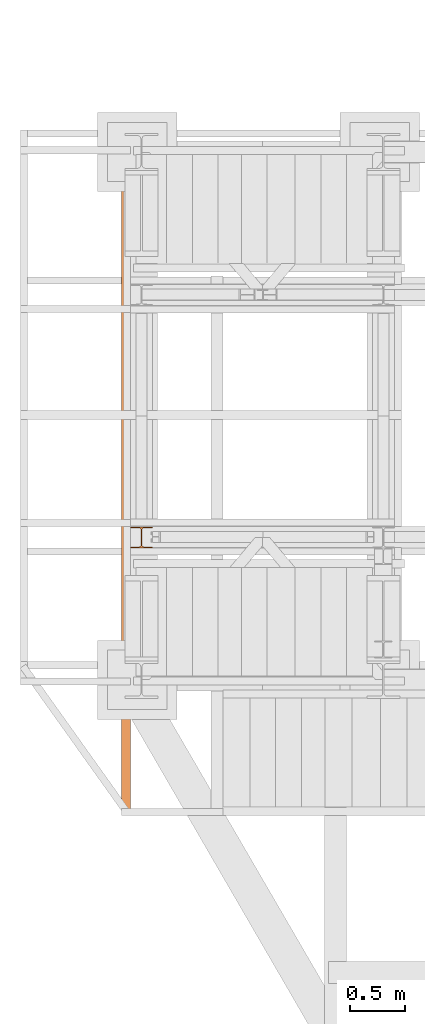
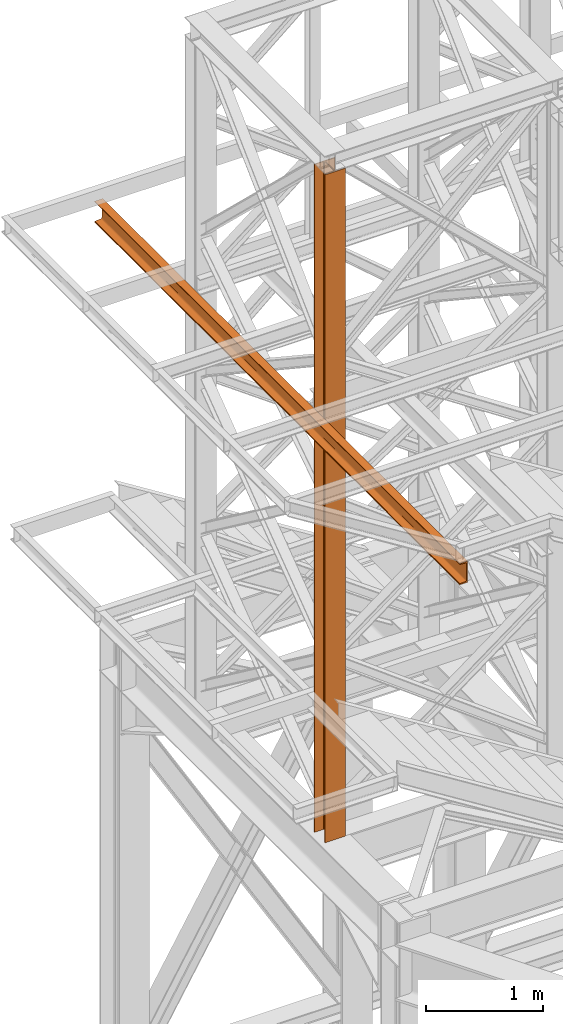
# One storey, part 83 of 208: 2 proxies.
"""IFC2X3 building model written with IfcOpenShell, lengths in millimetres."""

from ifc_helpers import new_model, entity, si_unit, converted_unit, frame, origin, origin_with_axes, place, context, subcontext, project, spatial, faceted_brep, element, save


model = new_model("IFC2X3")

# Units and contexts
model_context = context("Model", 3, precision=1e-05, world=origin())
plan_context = context("Plan", 3, precision=1e-05, world=origin())
body_context = subcontext(model_context, "Body", "Model", "MODEL_VIEW")
ifc_project = project(units=[si_unit("LENGTHUNIT", "METRE", prefix="MILLI"), converted_unit("PLANEANGLEUNIT", "DEGREE", entity("IfcPlaneAngleMeasure", 0.0174532925199433), si_unit("PLANEANGLEUNIT", "RADIAN"), dimensions=[0, 0, 0, 0, 0, 0, 0]), si_unit("AREAUNIT", "SQUARE_METRE"), si_unit("VOLUMEUNIT", "CUBIC_METRE")], contexts=[model_context, plan_context])

# Building, storey
building_placement = place(None, origin())
building = spatial("IfcBuilding", under=ifc_project, at=building_placement, CompositionType="COMPLEX")
storey_placement = place(building_placement, origin_with_axes())
storey = spatial("IfcBuildingStorey", under=building, at=storey_placement, Name="Geschoss", CompositionType="ELEMENT")

# Proxies
proxy_1_placement = place(storey_placement, frame((-3406.582754329113, -16062.574391808, 5284.990005364419), z_axis=(0.0, 0.0, 1.0), x_axis=(1.0, 0.0, 0.0)))
element("IfcBuildingElementProxy", 1, at=proxy_1_placement, inside=storey, context=body_context, shape_type="Brep", body=[
    faceted_brep([(0.01000000000021828, 190.0100125169756, 6965.010053329391), (200.0100029802325, 190.0100125169756, 6965.010053329391), (200.0100029802325, 180.0100146031382, 6965.010053329391), (121.2600035762789, 180.0100071525576, 6965.010053329391), (111.9441915473344, 178.1454621052744, 6965.010053329391), (105.1245498640838, 171.3258190250399, 6965.010053329391), (103.2600015571716, 162.010007927418, 6965.010053329391), (103.2600015571716, 28.00999713897727, 6965.010053329391), (105.1245498640838, 18.69418604135535, 6965.010053329391), (111.9441915473344, 11.87454296112082, 6965.010053329391), (121.2600035762789, 10.00999791383765, 6965.010053329391), (200.0100029802325, 10.00999791383765, 6965.010053329391), (200.0100029802325, 0.01000000000021828, 6965.010053329391), (0.01000000000021828, 0.01000000000021828, 6965.010053329391), (0.01000000000021828, 10.00999791383765, 6965.010053329391), (78.75999940395377, 10.00999791383765, 6965.010053329391), (88.07581143289826, 11.87454296112082, 6965.010053329391), (94.89545311614893, 18.69418604135535, 6965.010053329391), (96.76000142306111, 28.00999713897727, 6965.010053329391), (96.76000142306111, 162.010007927418, 6965.010053329391), (94.89545311614893, 171.3258190250399, 6965.010053329391), (88.07581143289826, 178.1454621052744, 6965.010053329391), (78.75999940395377, 180.0100071525576, 6965.010053329391), (0.01000000000021828, 180.0100146031382, 6965.010053329391), (200.0100029802325, 190.0100125169756, 6965.010053329391), (0.01000000000021828, 190.0100125169756, 6965.010053329391), (0.01000000000203727, 190.0100125169756, 0.009999999999308784), (200.0100029802343, 190.0100125169756, 0.009999999999308784), (200.0100029802325, 180.0100146031382, 6965.010053329391), (200.0100029802325, 190.0100125169756, 6965.010053329391), (200.0100029802343, 190.0100125169756, 0.009999999999308784), (200.0100029802343, 180.0100146031382, 0.009999999999308784), (121.2600035762789, 180.0100071525576, 6965.010053329391), (200.0100029802325, 180.0100146031382, 6965.010053329391), (200.0100029802343, 180.0100146031382, 0.009999999999308784), (121.2600035762807, 180.0100071525576, 0.009999999999308784), (111.9441915473344, 178.1454621052744, 6965.010053329391), (121.2600035762789, 180.0100071525576, 6965.010053329391), (121.2600035762807, 180.0100071525576, 0.009999999999308784), (111.9441915473362, 178.1454621052744, 0.009999999999308784), (105.1245498640838, 171.3258190250399, 6965.010053329391), (111.9441915473344, 178.1454621052744, 6965.010053329391), (111.9441915473362, 178.1454621052744, 0.009999999999308784), (105.1245498640856, 171.3258190250399, 0.009999999999308784), (103.2600015571716, 162.010007927418, 6965.010053329391), (105.1245498640838, 171.3258190250399, 6965.010053329391), (105.1245498640856, 171.3258190250399, 0.009999999999308784), (103.2600015571734, 162.010007927418, 0.009999999999308784), (103.2600015571716, 28.00999713897727, 6965.010053329391), (103.2600015571716, 162.010007927418, 6965.010053329391), (103.2600015571734, 162.010007927418, 0.009999999999308784), (103.2600015571734, 28.00999713897727, 0.009999999999308784), (105.1245498640838, 18.69418604135535, 6965.010053329391), (103.2600015571716, 28.00999713897727, 6965.010053329391), (103.2600015571734, 28.00999713897727, 0.009999999999308784), (105.1245498640856, 18.69418604135535, 0.009999999999308784), (111.9441915473344, 11.87454296112082, 6965.010053329391), (105.1245498640838, 18.69418604135535, 6965.010053329391), (105.1245498640856, 18.69418604135535, 0.009999999999308784), (111.9441915473362, 11.87454296112082, 0.009999999999308784), (121.2600035762789, 10.00999791383765, 6965.010053329391), (111.9441915473344, 11.87454296112082, 6965.010053329391), (111.9441915473362, 11.87454296112082, 0.009999999999308784), (121.2600035762807, 10.00999791383765, 0.009999999999308784), (200.0100029802325, 10.00999791383765, 6965.010053329391), (121.2600035762789, 10.00999791383765, 6965.010053329391), (121.2600035762807, 10.00999791383765, 0.009999999999308784), (200.0100029802343, 10.00999791383765, 0.009999999999308784), (200.0100029802325, 0.01000000000021828, 6965.010053329391), (200.0100029802325, 10.00999791383765, 6965.010053329391), (200.0100029802343, 10.00999791383765, 0.009999999999308784), (200.0100029802343, 0.01000000000021828, 0.009999999999308784), (0.01000000000021828, 0.01000000000021828, 6965.010053329391), (200.0100029802325, 0.01000000000021828, 6965.010053329391), (200.0100029802343, 0.01000000000021828, 0.009999999999308784), (0.01000000000203727, 0.01000000000021828, 0.009999999999308784), (0.01000000000021828, 10.00999791383765, 6965.010053329391), (0.01000000000021828, 0.01000000000021828, 6965.010053329391), (0.01000000000203727, 0.01000000000021828, 0.009999999999308784), (0.01000000000203727, 10.00999791383765, 0.009999999999308784), (78.75999940395377, 10.00999791383765, 6965.010053329391), (0.01000000000021828, 10.00999791383765, 6965.010053329391), (0.01000000000203727, 10.00999791383765, 0.009999999999308784), (78.75999940395559, 10.00999791383765, 0.009999999999308784), (88.07581143289826, 11.87454296112082, 6965.010053329391), (78.75999940395377, 10.00999791383765, 6965.010053329391), (78.75999940395559, 10.00999791383765, 0.009999999999308784), (88.07581143290008, 11.87454296112082, 0.009999999999308784), (94.89545311614893, 18.69418604135535, 6965.010053329391), (88.07581143289826, 11.87454296112082, 6965.010053329391), (88.07581143290008, 11.87454296112082, 0.009999999999308784), (94.89545311615075, 18.69418604135535, 0.009999999999308784), (96.76000142306111, 28.00999713897727, 6965.010053329391), (94.89545311614893, 18.69418604135535, 6965.010053329391), (94.89545311615075, 18.69418604135535, 0.009999999999308784), (96.76000142306293, 28.00999713897727, 0.009999999999308784), (96.76000142306111, 162.010007927418, 6965.010053329391), (96.76000142306111, 28.00999713897727, 6965.010053329391), (96.76000142306293, 28.00999713897727, 0.009999999999308784), (96.76000142306293, 162.010007927418, 0.009999999999308784), (94.89545311614893, 171.3258190250399, 6965.010053329391), (96.76000142306111, 162.010007927418, 6965.010053329391), (96.76000142306293, 162.010007927418, 0.009999999999308784), (94.89545311615075, 171.3258190250399, 0.009999999999308784), (88.07581143289826, 178.1454621052744, 6965.010053329391), (94.89545311614893, 171.3258190250399, 6965.010053329391), (94.89545311615075, 171.3258190250399, 0.009999999999308784), (88.07581143290008, 178.1454621052744, 0.009999999999308784), (78.75999940395377, 180.0100071525576, 6965.010053329391), (88.07581143289826, 178.1454621052744, 6965.010053329391), (88.07581143290008, 178.1454621052744, 0.009999999999308784), (78.75999940395559, 180.0100071525576, 0.009999999999308784), (0.01000000000021828, 180.0100146031382, 6965.010053329391), (78.75999940395377, 180.0100071525576, 6965.010053329391), (78.75999940395559, 180.0100071525576, 0.009999999999308784), (0.01000000000203727, 180.0100146031382, 0.009999999999308784), (0.01000000000021828, 190.0100125169756, 6965.010053329391), (0.01000000000021828, 180.0100146031382, 6965.010053329391), (0.01000000000203727, 180.0100146031382, 0.009999999999308784), (0.01000000000203727, 190.0100125169756, 0.009999999999308784), (0.01000000000203727, 190.0100125169756, 0.009999999999308784), (0.01000000000203727, 180.0100146031382, 0.009999999999308784), (78.75999940395559, 180.0100071525576, 0.009999999999308784), (88.07581143290008, 178.1454621052744, 0.009999999999308784), (94.89545311615075, 171.3258190250399, 0.009999999999308784), (96.76000142306293, 162.010007927418, 0.009999999999308784), (96.76000142306293, 28.00999713897727, 0.009999999999308784), (94.89545311615075, 18.69418604135535, 0.009999999999308784), (88.07581143290008, 11.87454296112082, 0.009999999999308784), (78.75999940395559, 10.00999791383765, 0.009999999999308784), (0.01000000000203727, 10.00999791383765, 0.009999999999308784), (0.01000000000203727, 0.01000000000021828, 0.009999999999308784), (200.0100029802343, 0.01000000000021828, 0.009999999999308784), (200.0100029802343, 10.00999791383765, 0.009999999999308784), (121.2600035762807, 10.00999791383765, 0.009999999999308784), (111.9441915473362, 11.87454296112082, 0.009999999999308784), (105.1245498640856, 18.69418604135535, 0.009999999999308784), (103.2600015571734, 28.00999713897727, 0.009999999999308784), (103.2600015571734, 162.010007927418, 0.009999999999308784), (105.1245498640856, 171.3258190250399, 0.009999999999308784), (111.9441915473362, 178.1454621052744, 0.009999999999308784), (121.2600035762807, 180.0100071525576, 0.009999999999308784), (200.0100029802343, 180.0100146031382, 0.009999999999308784), (200.0100029802343, 190.0100125169756, 0.009999999999308784)], [[[0, 1, 2, 3, 4, 5, 6, 7, 8, 9, 10, 11, 12, 13, 14, 15, 16, 17, 18, 19, 20, 21, 22, 23]], [[24, 25, 26, 27]], [[28, 29, 30, 31]], [[32, 33, 34, 35]], [[36, 37, 38, 39]], [[40, 41, 42, 43]], [[44, 45, 46, 47]], [[48, 49, 50, 51]], [[52, 53, 54, 55]], [[56, 57, 58, 59]], [[60, 61, 62, 63]], [[64, 65, 66, 67]], [[68, 69, 70, 71]], [[72, 73, 74, 75]], [[76, 77, 78, 79]], [[80, 81, 82, 83]], [[84, 85, 86, 87]], [[88, 89, 90, 91]], [[92, 93, 94, 95]], [[96, 97, 98, 99]], [[100, 101, 102, 103]], [[104, 105, 106, 107]], [[108, 109, 110, 111]], [[112, 113, 114, 115]], [[116, 117, 118, 119]], [[120, 121, 122, 123, 124, 125, 126, 127, 128, 129, 130, 131, 132, 133, 134, 135, 136, 137, 138, 139, 140, 141, 142, 143]]], orient=[[False], [False], [False], [False], [False], [False], [False], [False], [False], [False], [False], [False], [False], [False], [False], [False], [False], [False], [False], [False], [False], [False], [False], [False], [False], [False]]),
])
proxy_2_placement = place(storey_placement, frame((-3486.745032961433, -18497.5746220012, 9479.99), z_axis=(0.0, 0.0, 1.0), x_axis=(1.0, 0.0, 0.0)))
element("IfcBuildingElementProxy", 2, at=proxy_2_placement, inside=storey, context=body_context, shape_type="Brep", body=[
    faceted_brep([(0.4659155496847234, 6234.879120193393, 220.0100000000002), (0.01000000000021828, 0.00999999999839929, 220.0100000000002), (0.01000000000021828, 0.00999999999839929, 216.3507668260718), (0.4659155496847234, 6234.879120193393, 216.3507668260718), (0.4659155496847234, 6234.879120193393, 216.3507668260718), (0.01000000000021828, 0.00999999999839929, 216.3507668260718), (0.2968705002967909, 0.00999999999839929, 214.4411131085253), (0.752786049981296, 6234.879120193393, 214.4411131085253), (0.752786049981296, 6234.879120193393, 214.4411131085253), (0.2968705002967909, 0.00999999999839929, 214.4411131085253), (1.132098207624949, 0.00999999999839929, 212.7000047486563), (1.588013757309454, 6234.879120193393, 212.7000047486563), (1.588013757309454, 6234.879120193393, 212.7000047486563), (1.132098207624949, 0.00999999999839929, 212.7000047486563), (2.44200260908292, 0.00999999999839929, 211.281122986331), (2.897918158767425, 6234.879120193393, 211.281122986331), (2.897918158767425, 6234.879120193393, 211.281122986331), (2.44200260908292, 0.00999999999839929, 211.281122986331), (4.110960604608408, 0.00999999999839929, 210.3097101734329), (4.566876154294732, 6234.879120193393, 210.3097101734329), (4.566876154294732, 6234.879120193393, 210.3097101734329), (4.110960604608408, 0.00999999999839929, 210.3097101734329), (5.991656055161002, 0.00999999999839929, 209.8714675155879), (6.447571604847326, 6234.879120193393, 209.8714675155879), (6.447571604847326, 6234.879120193393, 209.8714675155879), (5.991656055161002, 0.00999999999839929, 209.8714675155879), (59.50681527853521, 0.00999999999839929, 205.5902547777168), (59.96273082822154, 6234.879120193393, 205.5902547777168), (59.96273082822154, 6234.879120193393, 205.5902547777168), (59.50681527853521, 0.00999999999839929, 205.5902547777168), (63.12353729883034, 0.00999999999839929, 204.7474804357062), (63.57945284851303, 6234.879120193393, 204.7474804357062), (63.57945284851303, 6234.879120193393, 204.7474804357062), (63.12353729883034, 0.00999999999839929, 204.7474804357062), (66.33307190561027, 0.00999999999839929, 202.8793788724415), (66.78898745529659, 6234.879120193393, 202.8793788724415), (66.78898745529659, 6234.879120193393, 202.8793788724415), (66.33307190561027, 0.00999999999839929, 202.8793788724415), (68.85211883149168, 0.00999999999839929, 200.1507600987407), (69.30803438117618, 6234.879120193393, 200.1507600987407), (69.30803438117618, 6234.879120193393, 200.1507600987407), (68.85211883149168, 0.00999999999839929, 200.1507600987407), (70.45832596096989, 0.00999999999839929, 196.8024747913005), (70.91424151065439, 6234.879120193393, 196.8024747913005), (70.91424151065439, 6234.879120193393, 196.8024747913005), (70.45832596096989, 0.00999999999839929, 196.8024747913005), (71.01000000000022, 0.00999999999839929, 193.1300637960158), (71.46591554968472, 6234.879120193393, 193.1300637960158), (71.46591554968472, 6234.879120193393, 193.1300637960158), (71.01000000000022, 0.00999999999839929, 193.1300637960158), (71.01000000000022, 0.00999999999839929, 26.88993620398469), (71.46591554968472, 6234.879120193393, 26.88993620398469), (71.46591554968472, 6234.879120193393, 26.88993620398469), (71.01000000000022, 0.00999999999839929, 26.88993620398469), (70.45832596096989, 0.00999999999839929, 23.21752520870177), (70.91424151065439, 6234.879120193393, 23.21752520870177), (70.91424151065439, 6234.879120193393, 23.21752520870177), (70.45832596096989, 0.00999999999839929, 23.21752520870177), (68.85211883149168, 0.00999999999839929, 19.86923990125979), (69.30803438117618, 6234.879120193393, 19.86923990125979), (69.30803438117618, 6234.879120193393, 19.86923990125979), (68.85211883149168, 0.00999999999839929, 19.86923990125979), (66.33307190561209, 0.00999999999839929, 17.14062112755892), (66.78898745529659, 6234.879120193393, 17.14062112755892), (66.78898745529659, 6234.879120193393, 17.14062112755892), (66.33307190561209, 0.00999999999839929, 17.14062112755892), (63.12353729883034, 0.00999999999839929, 15.27251956429427), (63.57945284851303, 6234.879120193393, 15.27251956429427), (63.57945284851303, 6234.879120193393, 15.27251956429427), (63.12353729883034, 0.00999999999839929, 15.27251956429427), (59.50681527853703, 0.00999999999839929, 14.4297452222836), (59.96273082822154, 6234.879120193393, 14.4297452222836), (59.96273082822154, 6234.879120193393, 14.4297452222836), (59.50681527853703, 0.00999999999839929, 14.4297452222836), (5.991656055161002, 0.00999999999839929, 10.1485324844125), (6.447571604847326, 6234.879120193393, 10.1485324844125), (6.447571604847326, 6234.879120193393, 10.1485324844125), (5.991656055161002, 0.00999999999839929, 10.1485324844125), (4.110960604608408, 0.00999999999839929, 9.710289826567532), (4.566876154294732, 6234.879120193393, 9.710289826567532), (4.566876154294732, 6234.879120193393, 9.710289826567532), (4.110960604608408, 0.00999999999839929, 9.710289826567532), (2.44200260908292, 0.00999999999839929, 8.73887701366948), (2.897918158767425, 6234.879120193393, 8.73887701366948), (2.897918158767425, 6234.879120193393, 8.73887701366948), (2.44200260908292, 0.00999999999839929, 8.73887701366948), (1.132098207624949, 0.00999999999839929, 7.319995251345972), (1.588013757309454, 6234.879120193393, 7.319995251345972), (1.588013757309454, 6234.879120193393, 7.319995251345972), (1.132098207624949, 0.00999999999839929, 7.319995251345972), (0.2968705002967909, 0.00999999999839929, 5.578886891475122), (0.752786049981296, 6234.879120193393, 5.578886891475122), (0.752786049981296, 6234.879120193393, 5.578886891475122), (0.2968705002967909, 0.00999999999839929, 5.578886891475122), (0.01000000000021828, 0.00999999999839929, 3.66923317392866), (0.4659155496847234, 6234.879120193393, 3.66923317392866), (0.4659155496847234, 6234.879120193393, 3.66923317392866), (0.01000000000021828, 0.00999999999839929, 3.66923317392866), (0.01000000000021828, 0.00999999999839929, 0.01000000000021828), (0.4659155496847234, 6234.879120193393, 0.01000000000021828), (0.4659155496847234, 6234.879120193393, 0.01000000000021828), (0.01000000000021828, 0.00999999999839929, 0.01000000000021828), (80.01000000000022, 0.00999999999839929, 0.01000000000021828), (80.46591554968472, 6234.879120193393, 0.01000000000021828), (80.46591554968472, 6234.879120193393, 0.01000000000021828), (80.01000000000022, 0.00999999999839929, 0.01000000000021828), (80.01000000000022, 0.00999999999839929, 220.0100000000002), (80.46591554968472, 6234.879120193393, 220.0100000000002), (80.46591554968472, 6234.879120193393, 220.0100000000002), (80.01000000000022, 0.00999999999839929, 220.0100000000002), (0.01000000000021828, 0.00999999999839929, 220.0100000000002), (0.4659155496847234, 6234.879120193393, 220.0100000000002), (0.4659155496847234, 6234.879120193393, 220.0100000000002), (0.4659155496847234, 6234.879120193393, 216.3507668260718), (0.752786049981296, 6234.879120193393, 214.4411131085253), (1.588013757309454, 6234.879120193393, 212.7000047486563), (2.897918158767425, 6234.879120193393, 211.281122986331), (4.566876154294732, 6234.879120193393, 210.3097101734329), (6.447571604847326, 6234.879120193393, 209.8714675155879), (59.96273082822154, 6234.879120193393, 205.5902547777168), (63.57945284851303, 6234.879120193393, 204.7474804357062), (66.78898745529659, 6234.879120193393, 202.8793788724415), (69.30803438117618, 6234.879120193393, 200.1507600987407), (70.91424151065439, 6234.879120193393, 196.8024747913005), (71.46591554968472, 6234.879120193393, 193.1300637960158), (71.46591554968472, 6234.879120193393, 26.88993620398469), (70.91424151065439, 6234.879120193393, 23.21752520870177), (69.30803438117618, 6234.879120193393, 19.86923990125979), (66.78898745529659, 6234.879120193393, 17.14062112755892), (63.57945284851303, 6234.879120193393, 15.27251956429427), (59.96273082822154, 6234.879120193393, 14.4297452222836), (6.447571604847326, 6234.879120193393, 10.1485324844125), (4.566876154294732, 6234.879120193393, 9.710289826567532), (2.897918158767425, 6234.879120193393, 8.73887701366948), (1.588013757309454, 6234.879120193393, 7.319995251345972), (0.752786049981296, 6234.879120193393, 5.578886891475122), (0.4659155496847234, 6234.879120193393, 3.66923317392866), (0.4659155496847234, 6234.879120193393, 0.01000000000021828), (80.46591554968472, 6234.879120193393, 0.01000000000021828), (80.46591554968472, 6234.879120193393, 220.0100000000002), (0.01000000000021828, 0.00999999999839929, 220.0100000000002), (80.01000000000022, 0.00999999999839929, 220.0100000000002), (80.01000000000022, 0.00999999999839929, 0.01000000000021828), (0.01000000000021828, 0.00999999999839929, 0.01000000000021828), (0.01000000000021828, 0.00999999999839929, 3.66923317392866), (0.2968705002967909, 0.00999999999839929, 5.578886891475122), (1.132098207624949, 0.00999999999839929, 7.319995251345972), (2.44200260908292, 0.00999999999839929, 8.73887701366948), (4.110960604608408, 0.00999999999839929, 9.710289826567532), (5.991656055161002, 0.00999999999839929, 10.1485324844125), (59.50681527853703, 0.00999999999839929, 14.4297452222836), (63.12353729883034, 0.00999999999839929, 15.27251956429427), (66.33307190561209, 0.00999999999839929, 17.14062112755892), (68.85211883149168, 0.00999999999839929, 19.86923990125979), (70.45832596096989, 0.00999999999839929, 23.21752520870177), (71.01000000000022, 0.00999999999839929, 26.88993620398469), (71.01000000000022, 0.00999999999839929, 193.1300637960158), (70.45832596096989, 0.00999999999839929, 196.8024747913005), (68.85211883149168, 0.00999999999839929, 200.1507600987407), (66.33307190561027, 0.00999999999839929, 202.8793788724415), (63.12353729883034, 0.00999999999839929, 204.7474804357062), (59.50681527853521, 0.00999999999839929, 205.5902547777168), (5.991656055161002, 0.00999999999839929, 209.8714675155879), (4.110960604608408, 0.00999999999839929, 210.3097101734329), (2.44200260908292, 0.00999999999839929, 211.281122986331), (1.132098207624949, 0.00999999999839929, 212.7000047486563), (0.2968705002967909, 0.00999999999839929, 214.4411131085253), (0.01000000000021828, 0.00999999999839929, 216.3507668260718)], [[[0, 1, 2, 3]], [[4, 5, 6, 7]], [[8, 9, 10, 11]], [[12, 13, 14, 15]], [[16, 17, 18, 19]], [[20, 21, 22, 23]], [[24, 25, 26, 27]], [[28, 29, 30, 31]], [[32, 33, 34, 35]], [[36, 37, 38, 39]], [[40, 41, 42, 43]], [[44, 45, 46, 47]], [[48, 49, 50, 51]], [[52, 53, 54, 55]], [[56, 57, 58, 59]], [[60, 61, 62, 63]], [[64, 65, 66, 67]], [[68, 69, 70, 71]], [[72, 73, 74, 75]], [[76, 77, 78, 79]], [[80, 81, 82, 83]], [[84, 85, 86, 87]], [[88, 89, 90, 91]], [[92, 93, 94, 95]], [[96, 97, 98, 99]], [[100, 101, 102, 103]], [[104, 105, 106, 107]], [[108, 109, 110, 111]], [[112, 113, 114, 115, 116, 117, 118, 119, 120, 121, 122, 123, 124, 125, 126, 127, 128, 129, 130, 131, 132, 133, 134, 135, 136, 137, 138, 139]], [[140, 141, 142, 143, 144, 145, 146, 147, 148, 149, 150, 151, 152, 153, 154, 155, 156, 157, 158, 159, 160, 161, 162, 163, 164, 165, 166, 167]]], orient=[[False], [False], [False], [False], [False], [False], [False], [False], [False], [False], [False], [False], [False], [False], [False], [False], [False], [False], [False], [False], [False], [False], [False], [False], [False], [False], [False], [False], [False], [False]]),
])

save(model, "model.ifc")
